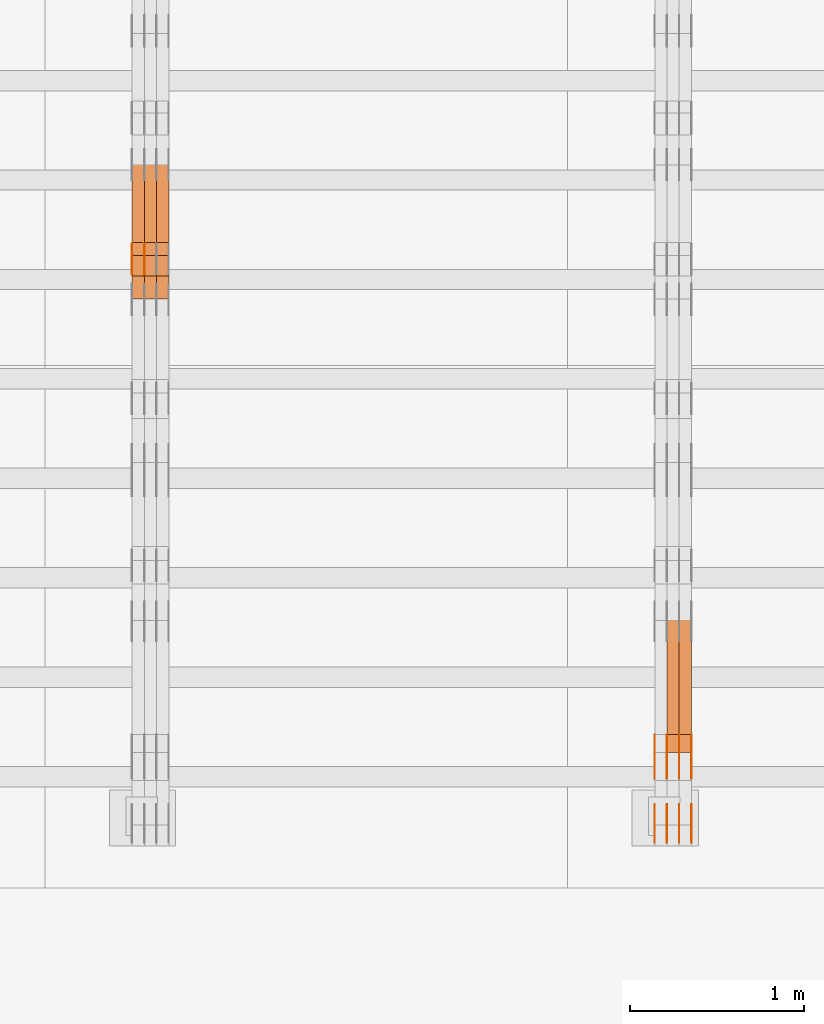
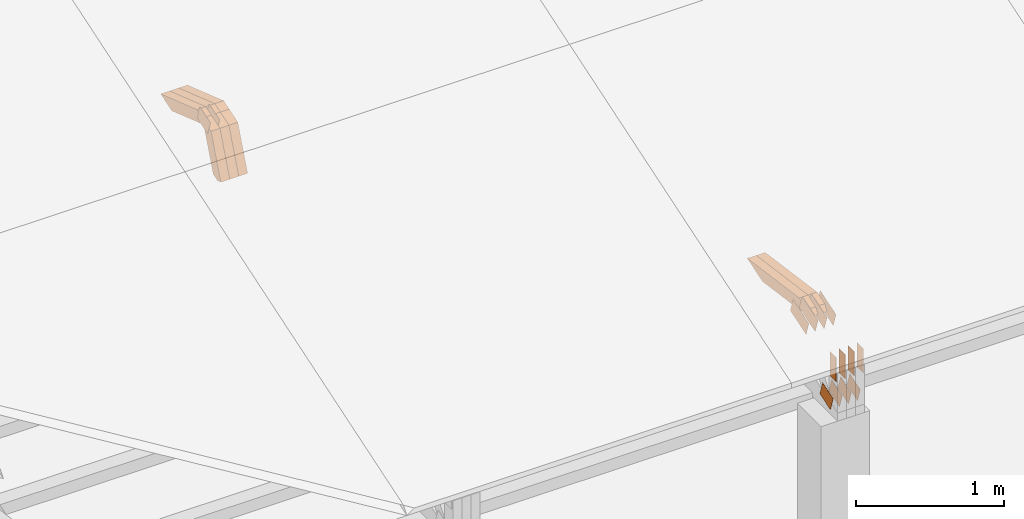
# One storey, part 111 of 385: 28 proxies.
"""IFC2X3 building model written with IfcOpenShell, lengths in millimetres."""

from ifc_helpers import new_model, entity, si_unit, converted_unit, derived_unit, direction, frame, frame_2d, origin, place, context, subcontext, project, spatial, polyline, rectangle, outline, extrude, source, transform, mapped, material, type_object, type_shapes, element, save


model = new_model("IFC2X3")

# Units and contexts
model_context = context("Model", 3, precision=0.01, world=origin(), true_north=direction((6.12303176911189e-17, 1.0)))
body_context = subcontext(model_context, "Body", "Model", "MODEL_VIEW")
ifc_project = project(units=[si_unit("LENGTHUNIT", "METRE", prefix="MILLI"), si_unit("AREAUNIT", "SQUARE_METRE"), si_unit("VOLUMEUNIT", "CUBIC_METRE"), converted_unit("PLANEANGLEUNIT", "DEGREE", entity("IfcRatioMeasure", 0.0174532925199433), si_unit("PLANEANGLEUNIT", "RADIAN"), dimensions=[0, 0, 0, 0, 0, 0, 0]), si_unit("MASSUNIT", "GRAM", prefix="KILO"), derived_unit("MASSDENSITYUNIT", [(si_unit("MASSUNIT", "GRAM", prefix="KILO"), 1), (si_unit("LENGTHUNIT", "METRE"), -3)]), si_unit("TIMEUNIT", "SECOND"), si_unit("FREQUENCYUNIT", "HERTZ"), si_unit("THERMODYNAMICTEMPERATUREUNIT", "DEGREE_CELSIUS"), derived_unit("THERMALTRANSMITTANCEUNIT", [(si_unit("MASSUNIT", "GRAM", prefix="KILO"), 1), (si_unit("THERMODYNAMICTEMPERATUREUNIT", "KELVIN"), -1), (si_unit("TIMEUNIT", "SECOND"), -3)]), derived_unit("VOLUMETRICFLOWRATEUNIT", [(si_unit("LENGTHUNIT", "METRE"), 3), (si_unit("TIMEUNIT", "SECOND"), -1)]), si_unit("ELECTRICCURRENTUNIT", "AMPERE"), si_unit("ELECTRICVOLTAGEUNIT", "VOLT"), si_unit("POWERUNIT", "WATT"), si_unit("FORCEUNIT", "NEWTON", prefix="KILO"), si_unit("ILLUMINANCEUNIT", "LUX"), si_unit("LUMINOUSFLUXUNIT", "LUMEN"), si_unit("LUMINOUSINTENSITYUNIT", "CANDELA"), derived_unit("USERDEFINED", [(si_unit("MASSUNIT", "GRAM", prefix="KILO"), -1), (si_unit("LENGTHUNIT", "METRE"), -2), (si_unit("TIMEUNIT", "SECOND"), 3), (si_unit("LUMINOUSFLUXUNIT", "LUMEN"), 1)]), derived_unit("LINEARVELOCITYUNIT", [(si_unit("LENGTHUNIT", "METRE"), 1), (si_unit("TIMEUNIT", "SECOND"), -1)]), si_unit("PRESSUREUNIT", "PASCAL"), derived_unit("USERDEFINED", [(si_unit("LENGTHUNIT", "METRE"), -2), (si_unit("MASSUNIT", "GRAM", prefix="KILO"), 1), (si_unit("TIMEUNIT", "SECOND"), -2)])], contexts=[model_context])

# Site, building, storey
site_placement = place(None, origin())
site = spatial("IfcSite", under=ifc_project, at=site_placement, CompositionType="ELEMENT")
building_placement = place(site_placement, origin())
building = spatial("IfcBuilding", under=site, at=building_placement, CompositionType="ELEMENT")
storey_placement = place(building_placement, origin())
storey = spatial("IfcBuildingStorey", under=building, at=storey_placement, Name="Default", CompositionType="ELEMENT", Elevation=0.0)

# Proxies
ifc_material_1 = material(Name="IfcSurfaceStyle #271164")
building_element_proxy_type_1 = type_object("IfcBuildingElementProxyType", PredefinedType="NOTDEFINED", material=ifc_material_1)
shared_shape_1 = source(origin(), body_context, "Body", "SweptSolid", [
    extrude(outline(polyline([(-74.999865408764, -60.0000379172698), (74.9998729365771, -60.0000379172698), (74.9998642299588, 60.0000379172698), (-74.9998717577719, 60.0000379172698), (-74.999865408764, -60.0000379172698)])), frame((75.0005044383734, 60.0001679035349, 0.0), z_axis=(0.0, 0.0, 1.0), x_axis=(-1.0, 0.0, 0.0)), (0.0, 0.0, 1.0), 1.3),
])
type_shapes(building_element_proxy_type_1, [shared_shape_1])
proxy_1_placement = place(building_placement, frame((21386.3, 2998.66143710397, 150.423871180894), z_axis=(-1.0, 0.0, 0.0), x_axis=(0.0, 0.951056516295124, 0.309016994375039)))
element("IfcBuildingElementProxy", 1, at=proxy_1_placement, inside=storey, type_object=building_element_proxy_type_1, material=ifc_material_1, context=body_context, shape_type="MappedRepresentation", body=[
    mapped(shared_shape_1, transform((0.0, 0.0, 0.0), scale=1.0)),
])
ifc_material_2 = material(Name="IfcSurfaceStyle #271107")
building_element_proxy_type_2 = type_object("IfcBuildingElementProxyType", PredefinedType="NOTDEFINED", material=ifc_material_2)
shared_shape_2 = source(origin(), body_context, "Body", "SweptSolid", [
    extrude(outline(polyline([(-74.999865408764, -60.0000379172698), (74.9998729365771, -60.0000379172698), (74.9998642299588, 60.0000379172698), (-74.9998717577719, 60.0000379172698), (-74.999865408764, -60.0000379172698)])), frame((75.0005044383734, 60.0001679035349, 0.0), z_axis=(0.0, 0.0, 1.0), x_axis=(-1.0, 0.0, 0.0)), (0.0, 0.0, 1.0), 1.3),
])
type_shapes(building_element_proxy_type_2, [shared_shape_2])
proxy_2_placement = place(building_placement, frame((21315.0, 2998.66143710397, 150.423871180894), z_axis=(-1.0, 0.0, 0.0), x_axis=(0.0, 0.951056516295124, 0.309016994375039)))
element("IfcBuildingElementProxy", 2, at=proxy_2_placement, inside=storey, type_object=building_element_proxy_type_2, material=ifc_material_2, context=body_context, shape_type="MappedRepresentation", body=[
    mapped(shared_shape_2, transform((0.0, 0.0, 0.0), scale=1.0)),
])
ifc_material_3 = material(Name="IfcSurfaceStyle #271050")
building_element_proxy_type_3 = type_object("IfcBuildingElementProxyType", PredefinedType="NOTDEFINED", material=ifc_material_3)
shared_shape_3 = source(origin(), body_context, "Body", "SweptSolid", [
    extrude(outline(polyline([(-74.999865408764, -60.0000379172698), (74.9998729365771, -60.0000379172698), (74.9998642299588, 60.0000379172698), (-74.9998717577719, 60.0000379172698), (-74.999865408764, -60.0000379172698)])), frame((75.0005044383734, 60.0001679035349, 0.0), z_axis=(0.0, 0.0, 1.0), x_axis=(-1.0, 0.0, 0.0)), (0.0, 0.0, 1.0), 1.3),
])
type_shapes(building_element_proxy_type_3, [shared_shape_3])
proxy_3_placement = place(building_placement, frame((21316.3, 2998.66143710397, 150.423871180894), z_axis=(-1.0, 0.0, 0.0), x_axis=(0.0, 0.951056516295124, 0.309016994375039)))
element("IfcBuildingElementProxy", 3, at=proxy_3_placement, inside=storey, type_object=building_element_proxy_type_3, material=ifc_material_3, context=body_context, shape_type="MappedRepresentation", body=[
    mapped(shared_shape_3, transform((0.0, 0.0, 0.0), scale=1.0)),
])
ifc_material_4 = material(Name="IfcSurfaceStyle #270993")
building_element_proxy_type_4 = type_object("IfcBuildingElementProxyType", PredefinedType="NOTDEFINED", material=ifc_material_4)
shared_shape_4 = source(origin(), body_context, "Body", "SweptSolid", [
    extrude(outline(polyline([(-74.999865408764, -60.0000379172698), (74.9998729365771, -60.0000379172698), (74.9998642299588, 60.0000379172698), (-74.9998717577719, 60.0000379172698), (-74.999865408764, -60.0000379172698)])), frame((75.0005044383734, 60.0001679035349, 0.0), z_axis=(0.0, 0.0, 1.0), x_axis=(-1.0, 0.0, 0.0)), (0.0, 0.0, 1.0), 1.29999999999999),
])
type_shapes(building_element_proxy_type_4, [shared_shape_4])
proxy_4_placement = place(building_placement, frame((21245.0, 2998.66143710397, 150.423871180894), z_axis=(-1.0, 0.0, 0.0), x_axis=(0.0, 0.951056516295124, 0.309016994375039)))
element("IfcBuildingElementProxy", 4, at=proxy_4_placement, inside=storey, type_object=building_element_proxy_type_4, material=ifc_material_4, context=body_context, shape_type="MappedRepresentation", body=[
    mapped(shared_shape_4, transform((0.0, 0.0, 0.0), scale=1.0)),
])
ifc_material_5 = material(Name="IfcSurfaceStyle #270936")
building_element_proxy_type_5 = type_object("IfcBuildingElementProxyType", PredefinedType="NOTDEFINED", material=ifc_material_5)
shared_shape_5 = source(origin(), body_context, "Body", "SweptSolid", [
    extrude(outline(polyline([(-74.999865408764, -60.0000379172698), (74.9998729365771, -60.0000379172698), (74.9998642299588, 60.0000379172698), (-74.9998717577719, 60.0000379172698), (-74.999865408764, -60.0000379172698)])), frame((75.0005044383734, 60.0001679035349, 0.0), z_axis=(0.0, 0.0, 1.0), x_axis=(-1.0, 0.0, 0.0)), (0.0, 0.0, 1.0), 1.29999999999999),
])
type_shapes(building_element_proxy_type_5, [shared_shape_5])
proxy_5_placement = place(building_placement, frame((21246.3, 2998.66143710397, 150.423871180894), z_axis=(-1.0, 0.0, 0.0), x_axis=(0.0, 0.951056516295124, 0.309016994375039)))
element("IfcBuildingElementProxy", 5, at=proxy_5_placement, inside=storey, type_object=building_element_proxy_type_5, material=ifc_material_5, context=body_context, shape_type="MappedRepresentation", body=[
    mapped(shared_shape_5, transform((0.0, 0.0, 0.0), scale=1.0)),
])
ifc_material_6 = material(Name="IfcSurfaceStyle #270879")
building_element_proxy_type_6 = type_object("IfcBuildingElementProxyType", PredefinedType="NOTDEFINED", material=ifc_material_6)
shared_shape_6 = source(origin(), body_context, "Body", "SweptSolid", [
    extrude(outline(polyline([(-74.999865408764, -60.0000379172698), (74.9998729365771, -60.0000379172698), (74.9998642299588, 60.0000379172698), (-74.9998717577719, 60.0000379172698), (-74.999865408764, -60.0000379172698)])), frame((75.0005044383734, 60.0001679035349, 0.0), z_axis=(0.0, 0.0, 1.0), x_axis=(-1.0, 0.0, 0.0)), (0.0, 0.0, 1.0), 1.29999999999999),
])
type_shapes(building_element_proxy_type_6, [shared_shape_6])
proxy_6_placement = place(building_placement, frame((21175.0, 2998.66143710397, 150.423871180894), z_axis=(-1.0, 0.0, 0.0), x_axis=(0.0, 0.951056516295124, 0.309016994375039)))
element("IfcBuildingElementProxy", 6, at=proxy_6_placement, inside=storey, type_object=building_element_proxy_type_6, material=ifc_material_6, context=body_context, shape_type="MappedRepresentation", body=[
    mapped(shared_shape_6, transform((0.0, 0.0, 0.0), scale=1.0)),
])
ifc_material_7 = material(Name="IfcSurfaceStyle #262614")
building_element_proxy_type_7 = type_object("IfcBuildingElementProxyType", PredefinedType="NOTDEFINED", material=ifc_material_7)
shared_shape_7 = source(origin(), body_context, "Body", "SweptSolid", [
    extrude(outline(polyline([(-112.500266735783, -59.9999130784581), (112.500275442392, -59.9999130784581), (112.500262020557, 59.9999130784582), (-112.500270727166, 59.9999130784581), (-112.500266735783, -59.9999130784581)])), frame((112.500275442392, 60.0001020984692, 0.0), z_axis=(0.0, 0.0, 1.0), x_axis=(-1.0, 0.0, 0.0)), (0.0, 0.0, 1.0), 1.3),
])
type_shapes(building_element_proxy_type_7, [shared_shape_7])
proxy_7_placement = place(building_placement, frame((21386.3, 3327.32420598508, 571.284602786019), z_axis=(-1.0, 0.0, 0.0), x_axis=(0.0, 0.951056516295154, 0.309016994374948)))
element("IfcBuildingElementProxy", 7, at=proxy_7_placement, inside=storey, type_object=building_element_proxy_type_7, material=ifc_material_7, context=body_context, shape_type="MappedRepresentation", body=[
    mapped(shared_shape_7, transform((0.0, 0.0, 0.0), scale=1.0)),
])
ifc_material_8 = material(Name="IfcSurfaceStyle #262557")
building_element_proxy_type_8 = type_object("IfcBuildingElementProxyType", PredefinedType="NOTDEFINED", material=ifc_material_8)
shared_shape_8 = source(origin(), body_context, "Body", "SweptSolid", [
    extrude(outline(polyline([(-112.500266735783, -59.9999130784581), (112.500275442392, -59.9999130784581), (112.500262020557, 59.9999130784582), (-112.500270727166, 59.9999130784581), (-112.500266735783, -59.9999130784581)])), frame((112.500275442392, 60.0001020984692, 0.0), z_axis=(0.0, 0.0, 1.0), x_axis=(-1.0, 0.0, 0.0)), (0.0, 0.0, 1.0), 1.3),
])
type_shapes(building_element_proxy_type_8, [shared_shape_8])
proxy_8_placement = place(building_placement, frame((21315.0, 3327.32420598508, 571.284602786019), z_axis=(-1.0, 0.0, 0.0), x_axis=(0.0, 0.951056516295154, 0.309016994374948)))
element("IfcBuildingElementProxy", 8, at=proxy_8_placement, inside=storey, type_object=building_element_proxy_type_8, material=ifc_material_8, context=body_context, shape_type="MappedRepresentation", body=[
    mapped(shared_shape_8, transform((0.0, 0.0, 0.0), scale=1.0)),
])
ifc_material_9 = material(Name="IfcSurfaceStyle #262500")
building_element_proxy_type_9 = type_object("IfcBuildingElementProxyType", PredefinedType="NOTDEFINED", material=ifc_material_9)
shared_shape_9 = source(origin(), body_context, "Body", "SweptSolid", [
    extrude(outline(polyline([(-112.500266735783, -59.9999130784581), (112.500275442392, -59.9999130784581), (112.500262020557, 59.9999130784582), (-112.500270727166, 59.9999130784581), (-112.500266735783, -59.9999130784581)])), frame((112.500275442392, 60.0001020984692, 0.0), z_axis=(0.0, 0.0, 1.0), x_axis=(-1.0, 0.0, 0.0)), (0.0, 0.0, 1.0), 1.3),
])
type_shapes(building_element_proxy_type_9, [shared_shape_9])
proxy_9_placement = place(building_placement, frame((21316.3, 3327.32420598508, 571.284602786019), z_axis=(-1.0, 0.0, 0.0), x_axis=(0.0, 0.951056516295154, 0.309016994374948)))
element("IfcBuildingElementProxy", 9, at=proxy_9_placement, inside=storey, type_object=building_element_proxy_type_9, material=ifc_material_9, context=body_context, shape_type="MappedRepresentation", body=[
    mapped(shared_shape_9, transform((0.0, 0.0, 0.0), scale=1.0)),
])
ifc_material_10 = material(Name="IfcSurfaceStyle #262443")
building_element_proxy_type_10 = type_object("IfcBuildingElementProxyType", PredefinedType="NOTDEFINED", material=ifc_material_10)
shared_shape_10 = source(origin(), body_context, "Body", "SweptSolid", [
    extrude(outline(polyline([(-112.500266735783, -59.9999130784581), (112.500275442392, -59.9999130784581), (112.500262020557, 59.9999130784582), (-112.500270727166, 59.9999130784581), (-112.500266735783, -59.9999130784581)])), frame((112.500275442392, 60.0001020984692, 0.0), z_axis=(0.0, 0.0, 1.0), x_axis=(-1.0, 0.0, 0.0)), (0.0, 0.0, 1.0), 1.29999999999998),
])
type_shapes(building_element_proxy_type_10, [shared_shape_10])
proxy_10_placement = place(building_placement, frame((21245.0, 3327.32420598508, 571.284602786019), z_axis=(-1.0, 0.0, 0.0), x_axis=(0.0, 0.951056516295154, 0.309016994374948)))
element("IfcBuildingElementProxy", 10, at=proxy_10_placement, inside=storey, type_object=building_element_proxy_type_10, material=ifc_material_10, context=body_context, shape_type="MappedRepresentation", body=[
    mapped(shared_shape_10, transform((0.0, 0.0, 0.0), scale=1.0)),
])
ifc_material_11 = material(Name="IfcSurfaceStyle #262386")
building_element_proxy_type_11 = type_object("IfcBuildingElementProxyType", PredefinedType="NOTDEFINED", material=ifc_material_11)
shared_shape_11 = source(origin(), body_context, "Body", "SweptSolid", [
    extrude(outline(polyline([(-112.500266735783, -59.9999130784581), (112.500275442392, -59.9999130784581), (112.500262020557, 59.9999130784582), (-112.500270727166, 59.9999130784581), (-112.500266735783, -59.9999130784581)])), frame((112.500275442392, 60.0001020984692, 0.0), z_axis=(0.0, 0.0, 1.0), x_axis=(-1.0, 0.0, 0.0)), (0.0, 0.0, 1.0), 1.29999999999998),
])
type_shapes(building_element_proxy_type_11, [shared_shape_11])
proxy_11_placement = place(building_placement, frame((21246.3, 3327.32420598508, 571.284602786019), z_axis=(-1.0, 0.0, 0.0), x_axis=(0.0, 0.951056516295154, 0.309016994374948)))
element("IfcBuildingElementProxy", 11, at=proxy_11_placement, inside=storey, type_object=building_element_proxy_type_11, material=ifc_material_11, context=body_context, shape_type="MappedRepresentation", body=[
    mapped(shared_shape_11, transform((0.0, 0.0, 0.0), scale=1.0)),
])
ifc_material_12 = material(Name="IfcSurfaceStyle #262329")
building_element_proxy_type_12 = type_object("IfcBuildingElementProxyType", PredefinedType="NOTDEFINED", material=ifc_material_12)
shared_shape_12 = source(origin(), body_context, "Body", "SweptSolid", [
    extrude(outline(polyline([(-112.500266735783, -59.9999130784581), (112.500275442392, -59.9999130784581), (112.500262020557, 59.9999130784582), (-112.500270727166, 59.9999130784581), (-112.500266735783, -59.9999130784581)])), frame((112.500275442392, 60.0001020984692, 0.0), z_axis=(0.0, 0.0, 1.0), x_axis=(-1.0, 0.0, 0.0)), (0.0, 0.0, 1.0), 1.29999999999999),
])
type_shapes(building_element_proxy_type_12, [shared_shape_12])
proxy_12_placement = place(building_placement, frame((21175.0, 3327.32420598508, 571.284602786019), z_axis=(-1.0, 0.0, 0.0), x_axis=(0.0, 0.951056516295154, 0.309016994374948)))
element("IfcBuildingElementProxy", 12, at=proxy_12_placement, inside=storey, type_object=building_element_proxy_type_12, material=ifc_material_12, context=body_context, shape_type="MappedRepresentation", body=[
    mapped(shared_shape_12, transform((0.0, 0.0, 0.0), scale=1.0)),
])
ifc_material_13 = material(Name="IfcSurfaceStyle #261588")
building_element_proxy_type_13 = type_object("IfcBuildingElementProxyType", PredefinedType="NOTDEFINED", material=ifc_material_13)
shared_shape_13 = source(origin(), body_context, "Body", "SweptSolid", [
    extrude(rectangle(XDim=199.999969482422, YDim=84.0, at=frame_2d((1.4210854715202e-14, 0.0), x_axis=(1.0, 0.0))), frame((100.000010815955, 42.0, 0.0), z_axis=(0.0, 0.0, 1.0), x_axis=(-1.0, 0.0, 0.0)), (0.0, 0.0, 1.0), 1.3),
])
type_shapes(building_element_proxy_type_13, [shared_shape_13])
proxy_13_placement = place(building_placement, frame((21386.3, 3042.0, 514.460048047401), z_axis=(-1.0, 0.0, 0.0), x_axis=(0.0, 0.0, -1.0)))
element("IfcBuildingElementProxy", 13, at=proxy_13_placement, inside=storey, type_object=building_element_proxy_type_13, material=ifc_material_13, context=body_context, shape_type="MappedRepresentation", body=[
    mapped(shared_shape_13, transform((0.0, 0.0, 0.0), scale=1.0)),
])
ifc_material_14 = material(Name="IfcSurfaceStyle #261531")
building_element_proxy_type_14 = type_object("IfcBuildingElementProxyType", PredefinedType="NOTDEFINED", material=ifc_material_14)
shared_shape_14 = source(origin(), body_context, "Body", "SweptSolid", [
    extrude(rectangle(XDim=199.999969482422, YDim=84.0, at=frame_2d((1.4210854715202e-14, 0.0), x_axis=(1.0, 0.0))), frame((100.000010815955, 42.0, 0.0), z_axis=(0.0, 0.0, 1.0), x_axis=(-1.0, 0.0, 0.0)), (0.0, 0.0, 1.0), 1.3),
])
type_shapes(building_element_proxy_type_14, [shared_shape_14])
proxy_14_placement = place(building_placement, frame((21315.0, 3042.0, 514.460048047401), z_axis=(-1.0, 0.0, 0.0), x_axis=(0.0, 0.0, -1.0)))
element("IfcBuildingElementProxy", 14, at=proxy_14_placement, inside=storey, type_object=building_element_proxy_type_14, material=ifc_material_14, context=body_context, shape_type="MappedRepresentation", body=[
    mapped(shared_shape_14, transform((0.0, 0.0, 0.0), scale=1.0)),
])
ifc_material_15 = material(Name="IfcSurfaceStyle #261474")
building_element_proxy_type_15 = type_object("IfcBuildingElementProxyType", PredefinedType="NOTDEFINED", material=ifc_material_15)
shared_shape_15 = source(origin(), body_context, "Body", "SweptSolid", [
    extrude(rectangle(XDim=199.999969482422, YDim=84.0, at=frame_2d((1.4210854715202e-14, 0.0), x_axis=(1.0, 0.0))), frame((100.000010815955, 42.0, 0.0), z_axis=(0.0, 0.0, 1.0), x_axis=(-1.0, 0.0, 0.0)), (0.0, 0.0, 1.0), 1.3),
])
type_shapes(building_element_proxy_type_15, [shared_shape_15])
proxy_15_placement = place(building_placement, frame((21316.3, 3042.0, 514.460048047401), z_axis=(-1.0, 0.0, 0.0), x_axis=(0.0, 0.0, -1.0)))
element("IfcBuildingElementProxy", 15, at=proxy_15_placement, inside=storey, type_object=building_element_proxy_type_15, material=ifc_material_15, context=body_context, shape_type="MappedRepresentation", body=[
    mapped(shared_shape_15, transform((0.0, 0.0, 0.0), scale=1.0)),
])
ifc_material_16 = material(Name="IfcSurfaceStyle #261417")
building_element_proxy_type_16 = type_object("IfcBuildingElementProxyType", PredefinedType="NOTDEFINED", material=ifc_material_16)
shared_shape_16 = source(origin(), body_context, "Body", "SweptSolid", [
    extrude(rectangle(XDim=199.999969482422, YDim=84.0, at=frame_2d((1.4210854715202e-14, 0.0), x_axis=(1.0, 0.0))), frame((100.000010815955, 42.0, 0.0), z_axis=(0.0, 0.0, 1.0), x_axis=(-1.0, 0.0, 0.0)), (0.0, 0.0, 1.0), 1.29999999999998),
])
type_shapes(building_element_proxy_type_16, [shared_shape_16])
proxy_16_placement = place(building_placement, frame((21245.0, 3042.0, 514.460048047401), z_axis=(-1.0, 0.0, 0.0), x_axis=(0.0, 0.0, -1.0)))
element("IfcBuildingElementProxy", 16, at=proxy_16_placement, inside=storey, type_object=building_element_proxy_type_16, material=ifc_material_16, context=body_context, shape_type="MappedRepresentation", body=[
    mapped(shared_shape_16, transform((0.0, 0.0, 0.0), scale=1.0)),
])
ifc_material_17 = material(Name="IfcSurfaceStyle #261360")
building_element_proxy_type_17 = type_object("IfcBuildingElementProxyType", PredefinedType="NOTDEFINED", material=ifc_material_17)
shared_shape_17 = source(origin(), body_context, "Body", "SweptSolid", [
    extrude(rectangle(XDim=199.999969482422, YDim=84.0, at=frame_2d((1.4210854715202e-14, 0.0), x_axis=(1.0, 0.0))), frame((100.000010815955, 42.0, 0.0), z_axis=(0.0, 0.0, 1.0), x_axis=(-1.0, 0.0, 0.0)), (0.0, 0.0, 1.0), 1.29999999999998),
])
type_shapes(building_element_proxy_type_17, [shared_shape_17])
proxy_17_placement = place(building_placement, frame((21246.3, 3042.0, 514.460048047401), z_axis=(-1.0, 0.0, 0.0), x_axis=(0.0, 0.0, -1.0)))
element("IfcBuildingElementProxy", 17, at=proxy_17_placement, inside=storey, type_object=building_element_proxy_type_17, material=ifc_material_17, context=body_context, shape_type="MappedRepresentation", body=[
    mapped(shared_shape_17, transform((0.0, 0.0, 0.0), scale=1.0)),
])
ifc_material_18 = material(Name="IfcSurfaceStyle #261303")
building_element_proxy_type_18 = type_object("IfcBuildingElementProxyType", PredefinedType="NOTDEFINED", material=ifc_material_18)
shared_shape_18 = source(origin(), body_context, "Body", "SweptSolid", [
    extrude(rectangle(XDim=199.999969482422, YDim=84.0, at=frame_2d((1.4210854715202e-14, 0.0), x_axis=(1.0, 0.0))), frame((100.000010815955, 42.0, 0.0), z_axis=(0.0, 0.0, 1.0), x_axis=(-1.0, 0.0, 0.0)), (0.0, 0.0, 1.0), 1.29999999999999),
])
type_shapes(building_element_proxy_type_18, [shared_shape_18])
proxy_18_placement = place(building_placement, frame((21175.0, 3042.0, 514.460048047401), z_axis=(-1.0, 0.0, 0.0), x_axis=(0.0, 0.0, -1.0)))
element("IfcBuildingElementProxy", 18, at=proxy_18_placement, inside=storey, type_object=building_element_proxy_type_18, material=ifc_material_18, context=body_context, shape_type="MappedRepresentation", body=[
    mapped(shared_shape_18, transform((0.0, 0.0, 0.0), scale=1.0)),
])
ifc_material_19 = material(Name="IfcSurfaceStyle #250320")
building_element_proxy_type_19 = type_object("IfcBuildingElementProxyType", Name="T1-W3 250318", PredefinedType="NOTDEFINED", material=ifc_material_19)
shared_shape_19 = source(origin(), body_context, "Body", "SweptSolid", [
    extrude(outline(polyline([(-314.232579911788, -47.5000200125938), (325.164873061766, -47.5000200125938), (297.999869081008, 6.48085173424295e-05), (200.434027234171, 47.4999876083351), (-509.366189465157, 47.4999876083352), (-314.232579911788, -47.5000200125938)])), frame((325.164873061766, 47.5001564752191, 0.0), z_axis=(0.0, 0.0, 1.0), x_axis=(-1.0, 0.0, 0.0)), (0.0, 0.0, 1.0), 70.0),
])
type_shapes(building_element_proxy_type_19, [shared_shape_19])
proxy_19_placement = place(building_placement, frame((21385.0, 3457.43747924875, 620.49890325051), z_axis=(-1.0, 0.0, 0.0), x_axis=(0.0, 0.990367219823621, -0.138465771578512)))
element("IfcBuildingElementProxy", 19, at=proxy_19_placement, inside=storey, type_object=building_element_proxy_type_19, material=ifc_material_19, Name="T1-W3", context=body_context, shape_type="MappedRepresentation", body=[
    mapped(shared_shape_19, transform((0.0, 0.0, 0.0), scale=1.0)),
])
ifc_material_20 = material(Name="IfcSurfaceStyle #250254")
building_element_proxy_type_20 = type_object("IfcBuildingElementProxyType", Name="T1-W3 250252", PredefinedType="NOTDEFINED", material=ifc_material_20)
shared_shape_20 = source(origin(), body_context, "Body", "SweptSolid", [
    extrude(outline(polyline([(-314.232579911788, -47.5000200125938), (325.164873061766, -47.5000200125938), (297.999869081008, 6.48085173424295e-05), (200.434027234171, 47.4999876083351), (-509.366189465157, 47.4999876083352), (-314.232579911788, -47.5000200125938)])), frame((325.164873061766, 47.5001564752191, 0.0), z_axis=(0.0, 0.0, 1.0), x_axis=(-1.0, 0.0, 0.0)), (0.0, 0.0, 1.0), 70.0),
])
type_shapes(building_element_proxy_type_20, [shared_shape_20])
proxy_20_placement = place(building_placement, frame((21315.0, 3457.43747924875, 620.49890325051), z_axis=(-1.0, 0.0, 0.0), x_axis=(0.0, 0.990367219823621, -0.138465771578512)))
element("IfcBuildingElementProxy", 20, at=proxy_20_placement, inside=storey, type_object=building_element_proxy_type_20, material=ifc_material_20, Name="T1-W3", context=body_context, shape_type="MappedRepresentation", body=[
    mapped(shared_shape_20, transform((0.0, 0.0, 0.0), scale=1.0)),
])
ifc_material_21 = material(Name="IfcSurfaceStyle #231032")
building_element_proxy_type_21 = type_object("IfcBuildingElementProxyType", PredefinedType="NOTDEFINED", material=ifc_material_21)
shared_shape_21 = source(origin(), body_context, "Body", "SweptSolid", [
    extrude(outline(polyline([(-74.9998754286253, -60.0000016373506), (74.999860559109, -60.0000016373506), (74.9998754286235, 60.0000016373506), (-74.9998605591072, 60.0000016373506), (-74.9998754286253, -60.0000016373506)])), frame((75.0001009411744, 60.0000279841752, 0.0), z_axis=(0.0, 0.0, 1.0), x_axis=(-1.0, 0.0, 0.0)), (0.0, 0.0, 1.0), 1.29999999999999),
])
type_shapes(building_element_proxy_type_21, [shared_shape_21])
proxy_21_placement = place(building_placement, frame((18246.3, 6218.29662915452, 1523.23574463408), z_axis=(-1.0, 0.0, 0.0), x_axis=(0.0, 0.951056516295154, 0.309016994374948)))
element("IfcBuildingElementProxy", 21, at=proxy_21_placement, inside=storey, type_object=building_element_proxy_type_21, material=ifc_material_21, context=body_context, shape_type="MappedRepresentation", body=[
    mapped(shared_shape_21, transform((0.0, 0.0, 0.0), scale=1.0)),
])
ifc_material_22 = material(Name="IfcSurfaceStyle #230975")
building_element_proxy_type_22 = type_object("IfcBuildingElementProxyType", PredefinedType="NOTDEFINED", material=ifc_material_22)
shared_shape_22 = source(origin(), body_context, "Body", "SweptSolid", [
    extrude(outline(polyline([(-74.9998754286253, -60.0000016373506), (74.999860559109, -60.0000016373506), (74.9998754286235, 60.0000016373506), (-74.9998605591072, 60.0000016373506), (-74.9998754286253, -60.0000016373506)])), frame((75.0001009411744, 60.0000279841752, 0.0), z_axis=(0.0, 0.0, 1.0), x_axis=(-1.0, 0.0, 0.0)), (0.0, 0.0, 1.0), 1.29999999999999),
])
type_shapes(building_element_proxy_type_22, [shared_shape_22])
proxy_22_placement = place(building_placement, frame((18175.0, 6218.29662915452, 1523.23574463408), z_axis=(-1.0, 0.0, 0.0), x_axis=(0.0, 0.951056516295154, 0.309016994374948)))
element("IfcBuildingElementProxy", 22, at=proxy_22_placement, inside=storey, type_object=building_element_proxy_type_22, material=ifc_material_22, context=body_context, shape_type="MappedRepresentation", body=[
    mapped(shared_shape_22, transform((0.0, 0.0, 0.0), scale=1.0)),
])
ifc_material_23 = material(Name="IfcSurfaceStyle #218264")
building_element_proxy_type_23 = type_object("IfcBuildingElementProxyType", Name="T1-W19 218262", PredefinedType="NOTDEFINED", material=ifc_material_23)
shared_shape_23 = source(origin(), body_context, "Body", "SweptSolid", [
    extrude(outline(polyline([(-234.986199656822, -47.5000587840676), (221.224626701627, -47.5000587840676), (219.29748584664, -9.04449542012076e-05), (156.014457007826, 47.5001040065446), (-361.550369899272, 47.5001040065447), (-234.986199656822, -47.5000587840676)])), frame((221.224626701627, 47.5001108598228, 0.0), z_axis=(0.0, 0.0, 1.0), x_axis=(-1.0, 0.0, 0.0)), (0.0, 0.0, 1.0), 70.0),
])
type_shapes(building_element_proxy_type_23, [shared_shape_23])
proxy_23_placement = place(building_placement, frame((18385.0, 6342.4042570111, 1541.63383639481), z_axis=(-1.0, 0.0, 0.0), x_axis=(0.0, 0.9461301511345, -0.323786561046329)))
element("IfcBuildingElementProxy", 23, at=proxy_23_placement, inside=storey, type_object=building_element_proxy_type_23, material=ifc_material_23, Name="T1-W19", context=body_context, shape_type="MappedRepresentation", body=[
    mapped(shared_shape_23, transform((0.0, 0.0, 0.0), scale=1.0)),
])
ifc_material_24 = material(Name="IfcSurfaceStyle #218198")
building_element_proxy_type_24 = type_object("IfcBuildingElementProxyType", Name="T1-W19 218196", PredefinedType="NOTDEFINED", material=ifc_material_24)
shared_shape_24 = source(origin(), body_context, "Body", "SweptSolid", [
    extrude(outline(polyline([(-234.986199656822, -47.5000587840676), (221.224626701627, -47.5000587840676), (219.29748584664, -9.04449542012076e-05), (156.014457007826, 47.5001040065446), (-361.550369899272, 47.5001040065447), (-234.986199656822, -47.5000587840676)])), frame((221.224626701627, 47.5001108598228, 0.0), z_axis=(0.0, 0.0, 1.0), x_axis=(-1.0, 0.0, 0.0)), (0.0, 0.0, 1.0), 70.0),
])
type_shapes(building_element_proxy_type_24, [shared_shape_24])
proxy_24_placement = place(building_placement, frame((18315.0, 6342.4042570111, 1541.63383639481), z_axis=(-1.0, 0.0, 0.0), x_axis=(0.0, 0.9461301511345, -0.323786561046329)))
element("IfcBuildingElementProxy", 24, at=proxy_24_placement, inside=storey, type_object=building_element_proxy_type_24, material=ifc_material_24, Name="T1-W19", context=body_context, shape_type="MappedRepresentation", body=[
    mapped(shared_shape_24, transform((0.0, 0.0, 0.0), scale=1.0)),
])
ifc_material_25 = material(Name="IfcSurfaceStyle #218132")
building_element_proxy_type_25 = type_object("IfcBuildingElementProxyType", Name="T1-W19 218130", PredefinedType="NOTDEFINED", material=ifc_material_25)
shared_shape_25 = source(origin(), body_context, "Body", "SweptSolid", [
    extrude(outline(polyline([(-234.986199656822, -47.5000587840676), (221.224626701627, -47.5000587840676), (219.29748584664, -9.04449542012076e-05), (156.014457007826, 47.5001040065446), (-361.550369899272, 47.5001040065447), (-234.986199656822, -47.5000587840676)])), frame((221.224626701627, 47.5001108598228, 0.0), z_axis=(0.0, 0.0, 1.0), x_axis=(-1.0, 0.0, 0.0)), (0.0, 0.0, 1.0), 70.0),
])
type_shapes(building_element_proxy_type_25, [shared_shape_25])
proxy_25_placement = place(building_placement, frame((18245.0, 6342.4042570111, 1541.63383639481), z_axis=(-1.0, 0.0, 0.0), x_axis=(0.0, 0.9461301511345, -0.323786561046329)))
element("IfcBuildingElementProxy", 25, at=proxy_25_placement, inside=storey, type_object=building_element_proxy_type_25, material=ifc_material_25, Name="T1-W19", context=body_context, shape_type="MappedRepresentation", body=[
    mapped(shared_shape_25, transform((0.0, 0.0, 0.0), scale=1.0)),
])
ifc_material_26 = material(Name="IfcSurfaceStyle #217868")
building_element_proxy_type_26 = type_object("IfcBuildingElementProxyType", Name="T1-W46 217866", PredefinedType="NOTDEFINED", material=ifc_material_26)
shared_shape_26 = source(origin(), body_context, "Body", "SweptSolid", [
    extrude(outline(polyline([(-272.224583017384, -47.5002947748381), (128.798007350946, -47.5002947748382), (167.560249082673, 0.000339032424879266), (170.567132940603, 47.500741369691), (-194.700806356838, 47.4995091475604), (-272.224583017384, -47.5002947748381)])), frame((170.567293182179, 47.5001659655231, 0.0), z_axis=(0.0, 0.0, 1.0), x_axis=(-1.0, 3.37347464168628e-06, 0.0)), (0.0, 0.0, 1.0), 70.0),
])
type_shapes(building_element_proxy_type_26, [shared_shape_26])
proxy_26_placement = place(building_placement, frame((18385.0, 6080.046875, 1117.66674804688), z_axis=(-1.0, 0.0, 0.0), x_axis=(0.0, 0.361885618189232, 0.93222250527854)))
element("IfcBuildingElementProxy", 26, at=proxy_26_placement, inside=storey, type_object=building_element_proxy_type_26, material=ifc_material_26, Name="T1-W46", context=body_context, shape_type="MappedRepresentation", body=[
    mapped(shared_shape_26, transform((0.0, 0.0, 0.0), scale=1.0)),
])
ifc_material_27 = material(Name="IfcSurfaceStyle #217802")
building_element_proxy_type_27 = type_object("IfcBuildingElementProxyType", Name="T1-W46 217800", PredefinedType="NOTDEFINED", material=ifc_material_27)
shared_shape_27 = source(origin(), body_context, "Body", "SweptSolid", [
    extrude(outline(polyline([(-272.224583017384, -47.5002947748381), (128.798007350946, -47.5002947748382), (167.560249082673, 0.000339032424879266), (170.567132940603, 47.500741369691), (-194.700806356838, 47.4995091475604), (-272.224583017384, -47.5002947748381)])), frame((170.567293182179, 47.5001659655231, 0.0), z_axis=(0.0, 0.0, 1.0), x_axis=(-1.0, 3.37347464168628e-06, 0.0)), (0.0, 0.0, 1.0), 70.0),
])
type_shapes(building_element_proxy_type_27, [shared_shape_27])
proxy_27_placement = place(building_placement, frame((18315.0, 6080.046875, 1117.66674804688), z_axis=(-1.0, 0.0, 0.0), x_axis=(0.0, 0.361885618189232, 0.93222250527854)))
element("IfcBuildingElementProxy", 27, at=proxy_27_placement, inside=storey, type_object=building_element_proxy_type_27, material=ifc_material_27, Name="T1-W46", context=body_context, shape_type="MappedRepresentation", body=[
    mapped(shared_shape_27, transform((0.0, 0.0, 0.0), scale=1.0)),
])
ifc_material_28 = material(Name="IfcSurfaceStyle #217736")
building_element_proxy_type_28 = type_object("IfcBuildingElementProxyType", Name="T1-W46 217734", PredefinedType="NOTDEFINED", material=ifc_material_28)
shared_shape_28 = source(origin(), body_context, "Body", "SweptSolid", [
    extrude(outline(polyline([(-272.224583017384, -47.5002947748381), (128.798007350946, -47.5002947748382), (167.560249082673, 0.000339032424879266), (170.567132940603, 47.500741369691), (-194.700806356838, 47.4995091475604), (-272.224583017384, -47.5002947748381)])), frame((170.567293182179, 47.5001659655231, 0.0), z_axis=(0.0, 0.0, 1.0), x_axis=(-1.0, 3.37347464168628e-06, 0.0)), (0.0, 0.0, 1.0), 70.0),
])
type_shapes(building_element_proxy_type_28, [shared_shape_28])
proxy_28_placement = place(building_placement, frame((18245.0, 6080.046875, 1117.66674804688), z_axis=(-1.0, 0.0, 0.0), x_axis=(0.0, 0.361885618189232, 0.93222250527854)))
element("IfcBuildingElementProxy", 28, at=proxy_28_placement, inside=storey, type_object=building_element_proxy_type_28, material=ifc_material_28, Name="T1-W46", context=body_context, shape_type="MappedRepresentation", body=[
    mapped(shared_shape_28, transform((0.0, 0.0, 0.0), scale=1.0)),
])

save(model, "model.ifc")
